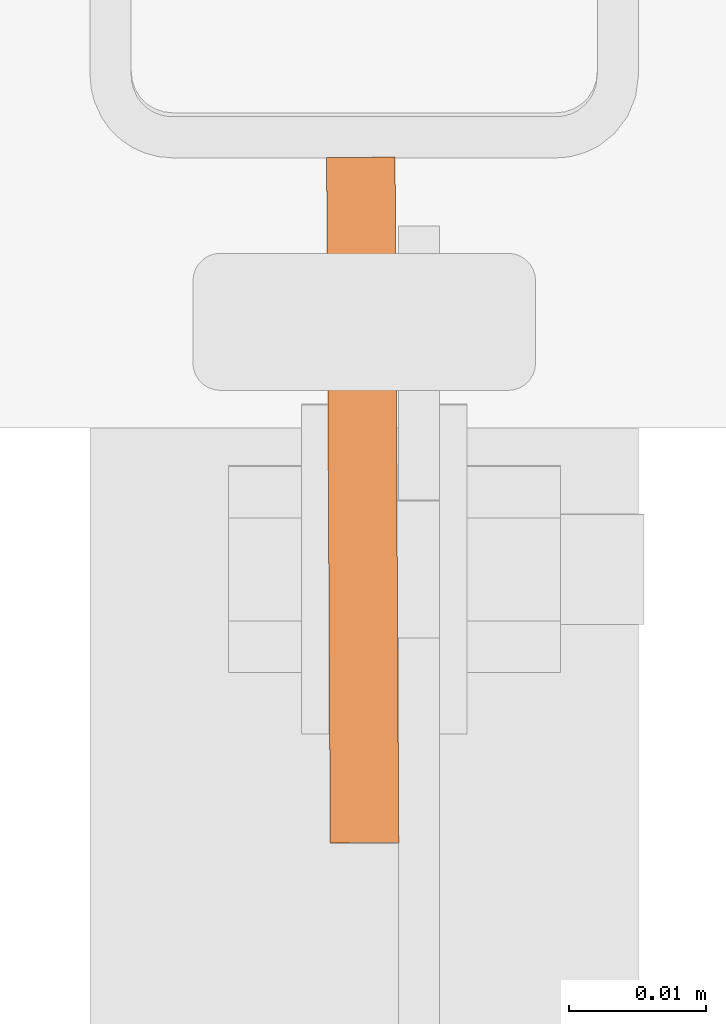
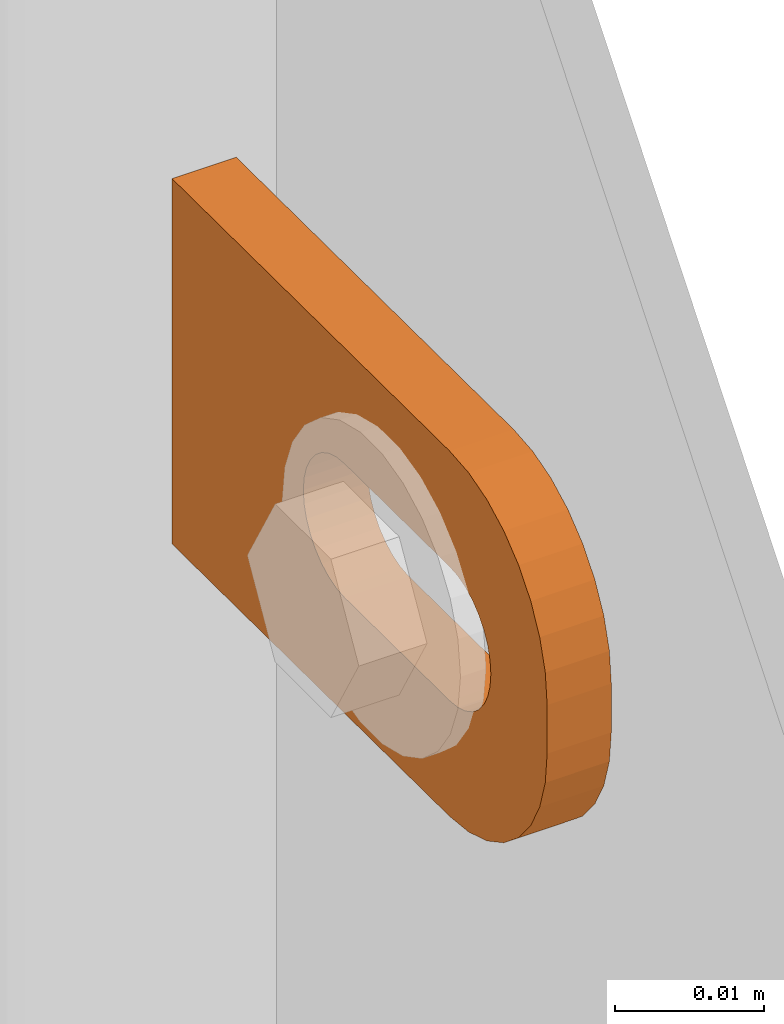
# One storey, part 132 of 156: 1 proxy, 1 element without a shape of its own.
"""IFC2X3 building model written with IfcOpenShell, lengths in millimetres."""

import ifcopenshell
import ifcopenshell.guid

model = None  # the IFC model being written
_history = None  # IfcOwnerHistory: only IFC2X3 demands one
_inside = {}  # id of a spatial element -> (the spatial element, [elements in it])
_under = {}  # id of a project, library or spatial element -> (it, [spatial elements below it])
_declared = {}  # id of a project -> (the project, [libraries it declares])
_typed = {}  # id of a type object -> (the type object, [elements of that type])
_made_of = {}  # id of a material, layer set ... -> (it, [elements and type objects made of it])


def new_model(schema):
    """Start an empty IFC model of exactly this schema.

    Asked for "IFC4X3", IfcOpenShell would pick the latest addendum, in which some entities
    have other attributes; the version numbers below select the first issue.
    IFC2X3 requires an IfcOwnerHistory on every rooted entity: one is made here for all.
    """
    global model, _history
    if schema == "IFC4X3":
        model = ifcopenshell.file(schema_version=(4, 3, 0, 0))
    else:
        model = ifcopenshell.file(schema=schema)
    _inside.clear()
    _under.clear()
    _declared.clear()
    _typed.clear()
    _made_of.clear()
    _history = None
    if model.schema == "IFC2X3":
        org = make("IfcOrganization", Name="unknown")
        user = make(
            "IfcPersonAndOrganization",
            ThePerson=make("IfcPerson", FamilyName="unknown"),
            TheOrganization=org,
        )
        app = make(
            "IfcApplication",
            ApplicationDeveloper=org,
            Version="unknown",
            ApplicationFullName="unknown",
            ApplicationIdentifier="unknown",
        )
        _history = make(
            "IfcOwnerHistory",
            OwningUser=user,
            OwningApplication=app,
            ChangeAction="ADDED",
            CreationDate=0,
        )
    return model


def make(cls, **values):
    """One entity of the class cls with the attributes given. An attribute that is None is left unset."""
    return model.create_entity(
        cls, **{name: value for name, value in values.items() if value is not None}
    )


def rooted(cls, **values):
    """An entity with a GlobalId (a new one), such as an element, a storey or a relation."""
    return make(cls, GlobalId=ifcopenshell.guid.new(), OwnerHistory=_history, **values)


def si_unit(unit_type, name, prefix=None):
    """IfcSIUnit, for example si_unit("LENGTHUNIT", "METRE", prefix="MILLI")."""
    return make("IfcSIUnit", UnitType=unit_type, Prefix=prefix, Name=name)


def assignment(units):
    """IfcUnitAssignment: the units of a project."""
    return None if units is None else make("IfcUnitAssignment", Units=units)


def point(xyz):
    """IfcCartesianPoint."""
    return None if xyz is None else make("IfcCartesianPoint", Coordinates=xyz)


def direction(xyz):
    """IfcDirection."""
    return None if xyz is None else make("IfcDirection", DirectionRatios=xyz)


def frame(location, z_axis=None, x_axis=None):
    """IfcAxis2Placement3D, a coordinate frame: its origin and axes. An axis left out is left unset."""
    return make(
        "IfcAxis2Placement3D",
        Location=point(location),
        Axis=direction(z_axis),
        RefDirection=direction(x_axis),
    )


def origin_with_axes():
    """The frame at (0, 0, 0) with the z axis (0, 0, 1) and the x axis (1, 0, 0) written out."""
    return frame((0.0, 0.0, 0.0), z_axis=(0.0, 0.0, 1.0), x_axis=(1.0, 0.0, 0.0))


def place(relative_to, where):
    """IfcLocalPlacement: puts the frame where relative to a parent placement (None: the world)."""
    return make(
        "IfcLocalPlacement", PlacementRelTo=relative_to, RelativePlacement=where
    )


def context(
    kind, dimensions, precision=None, world=None, true_north=None, identifier=None
):
    """IfcGeometricRepresentationContext, for example the 3D "Model" context."""
    return make(
        "IfcGeometricRepresentationContext",
        ContextIdentifier=identifier,
        ContextType=kind,
        CoordinateSpaceDimension=dimensions,
        Precision=precision,
        WorldCoordinateSystem=world,
        TrueNorth=true_north,
    )


def subcontext(parent, identifier, kind, view, scale=None):
    """IfcGeometricRepresentationSubContext, for example "Body" below "Model"."""
    return make(
        "IfcGeometricRepresentationSubContext",
        ContextIdentifier=identifier,
        ContextType=kind,
        ParentContext=parent,
        TargetScale=scale,
        TargetView=view,
    )


def project(units=None, contexts=None):
    """IfcProject with its units and contexts."""
    return rooted(
        "IfcProject",
        Name="project",
        RepresentationContexts=contexts,
        UnitsInContext=assignment(units),
    )


def spatial(cls, under=None, at=None, **own):
    """A site, building, storey or space (cls), placed at a placement, below another one or the project."""
    s = rooted(cls, ObjectPlacement=at, **own)
    if under is not None:
        _under.setdefault(under.id(), (under, []))[1].append(s)
    return s


def faces_of(points, faces, orient=None, outer=None):
    """IfcFace entities. A face is a list of loops; a loop is a list of indices into points, from 0.

    orient and outer hold one flag for each loop. By default every Orientation is true, the
    first loop of a face is its IfcFaceOuterBound and the others are IfcFaceBound.
    """
    made = []
    for i, loops in enumerate(faces):
        bounds = []
        for j, loop in enumerate(loops):
            is_outer = j == 0 if outer is None else outer[i][j]
            bounds.append(
                make(
                    "IfcFaceOuterBound" if is_outer else "IfcFaceBound",
                    Bound=make("IfcPolyLoop", Polygon=[points[k] for k in loop]),
                    Orientation=True if orient is None else orient[i][j],
                )
            )
        made.append(make("IfcFace", Bounds=bounds))
    return made


def faceted_brep(points, faces, orient=None, outer=None, voids=None):
    """IfcFacetedBrep: a solid bounded by flat faces; with voids (closed shells), ...WithVoids."""
    shared = [point(p) for p in points]
    hull = make("IfcClosedShell", CfsFaces=faces_of(shared, faces, orient, outer))
    if voids is None:
        return make("IfcFacetedBrep", Outer=hull)
    return make(
        "IfcFacetedBrepWithVoids",
        Outer=hull,
        Voids=[
            make(cls, CfsFaces=faces_of(shared, fs, o, b)) for cls, fs, o, b in voids
        ],
    )


def shape(context_of_items, identifier, shape_type, items):
    """IfcShapeRepresentation: the items that make up one representation, for example the "Body"."""
    return make(
        "IfcShapeRepresentation",
        ContextOfItems=context_of_items,
        RepresentationIdentifier=identifier,
        RepresentationType=shape_type,
        Items=items,
    )


def material(Name=None, Category=None):
    """IfcMaterial."""
    return make("IfcMaterial", Name=Name, Category=Category)


def made_of(thing, what):
    """Note that an element or type object is made of a material, layer set ...; save() writes the relation."""
    if what is not None:
        _made_of.setdefault(what.id(), (what, []))[1].append(thing)
    return thing


def type_object(cls, material=None, **own):
    """A type object (cls), such as IfcWallType, which elements share."""
    return made_of(rooted(cls, **own), material)


def element(
    cls,
    number,
    at=None,
    inside=None,
    cuts=None,
    type_object=None,
    material=None,
    context=None,
    identifier="Body",
    shape_type=None,
    held_by="IfcProductDefinitionShape",
    body=None,
    shapes=None,
    **own,
):
    """One element of the class cls, such as IfcWall. Its Tag is "e" and its number.

    at: its placement. inside: the storey or other place that contains it. cuts: it is an
    opening in that element (IfcRelVoidsElement). A single representation is given by context,
    identifier, shape_type and body (its items); several are given by shapes. held_by: the class
    of the entity that holds the representations. save() writes the other relations.
    """
    e = rooted(cls, Tag="e%d" % number, ObjectPlacement=at, **own)
    if body is not None:
        shapes = [shape(context, identifier, shape_type, body)]
    if shapes is not None:
        e.Representation = make(held_by, Representations=shapes)
    if inside is not None:
        _inside.setdefault(inside.id(), (inside, []))[1].append(e)
    if cuts is not None:
        rooted(
            "IfcRelVoidsElement", RelatingBuildingElement=cuts, RelatedOpeningElement=e
        )
    if type_object is not None:
        _typed.setdefault(type_object.id(), (type_object, []))[1].append(e)
    return made_of(e, material)


def aggregate(whole, parts):
    """IfcRelAggregates: a whole, such as a stair, and the parts it consists of."""
    return rooted("IfcRelAggregates", RelatingObject=whole, RelatedObjects=parts)


def save(model, path):
    """Write the relations noted so far, then the file.

    IfcRelAggregates (storeys below a building ...), IfcRelContainedInSpatialStructure (elements
    in a storey), IfcRelDefinesByType, IfcRelAssociatesMaterial and IfcRelDeclares: one each for
    every whole, place, type object, material and project.
    """
    for whole, parts in _under.values():
        aggregate(whole, parts)
    for where, things in _inside.values():
        rooted(
            "IfcRelContainedInSpatialStructure",
            RelatedElements=things,
            RelatingStructure=where,
        )
    for kind, things in _typed.values():
        rooted("IfcRelDefinesByType", RelatedObjects=things, RelatingType=kind)
    for what, things in _made_of.values():
        rooted("IfcRelAssociatesMaterial", RelatedObjects=things, RelatingMaterial=what)
    for by, libraries in _declared.values():
        rooted("IfcRelDeclares", RelatingContext=by, RelatedDefinitions=libraries)
    model.write(path)


model = new_model("IFC2X3")

# Units and contexts
model_context = context("Model", 3, precision=1e-05, world=origin_with_axes())
body_context = subcontext(model_context, "Body", "Model", "MODEL_VIEW")
ifc_project = project(units=[si_unit("LENGTHUNIT", "METRE", prefix="MILLI"), si_unit("AREAUNIT", "SQUARE_METRE"), si_unit("VOLUMEUNIT", "CUBIC_METRE"), si_unit("MASSUNIT", "GRAM", prefix="KILO"), si_unit("TIMEUNIT", "SECOND"), si_unit("PLANEANGLEUNIT", "RADIAN"), si_unit("SOLIDANGLEUNIT", "STERADIAN"), si_unit("THERMODYNAMICTEMPERATUREUNIT", "DEGREE_CELSIUS"), si_unit("LUMINOUSINTENSITYUNIT", "LUMEN")], contexts=[model_context])

# Site, building, storey
site_placement = place(None, origin_with_axes())
site = spatial("IfcSite", under=ifc_project, at=site_placement, CompositionType="ELEMENT")
building_placement = place(site_placement, origin_with_axes())
building = spatial("IfcBuilding", under=site, at=building_placement, Name="Undefined", CompositionType="ELEMENT")
storey_placement = place(building_placement, origin_with_axes())
storey = spatial("IfcBuildingStorey", under=building, at=storey_placement, Name="Undefined", CompositionType="ELEMENT", Elevation=0.0)

# Assembly, proxy
assembly_placement = place(storey_placement, origin_with_axes())
assembly = element("IfcElementAssembly", 1, at=assembly_placement, inside=storey, AssemblyPlace="NOTDEFINED", PredefinedType="RIGID_FRAME")
ifc_material = material(Name="STEEL/S235JR")
building_element_proxy_type = type_object("IfcBuildingElementProxyType", Name="50", PredefinedType="NOTDEFINED")
proxy_placement = place(assembly_placement, frame((14799.75, 23368.0068367617, 3194.79276353919), z_axis=(-0.999985556002151, -0.00537473600001249, 0.0), x_axis=(0.00537473600001187, -0.999985556002151, 1.19999999540802e-08)))
proxy = element("IfcBuildingElementProxy", 2, at=proxy_placement, type_object=building_element_proxy_type, material=ifc_material, ObjectType="50", CompositionType="ELEMENT", context=body_context, shape_type="Brep", body=[
    faceted_brep([(37.0000004768226, -5.50000056624776, -2.49999994410609), (23.0000000446889, -5.50000056624594, -2.49999994410973), (23.0000000446889, -5.50000056624594, 2.49999994413156), (37.000000476819, -5.50000056624776, 2.49999994413338), (21.9270028173814, -5.39431966841403, -2.49999994410973), (21.9270028173778, -5.39431966841403, 2.49999994412792), (20.895240828384, -5.0813375413436, -2.49999994411155), (20.895240828384, -5.0813375413436, 2.49999994412974), (19.9443642049955, -4.5730831474084, -2.49999994410973), (19.9443642049919, -4.5730831474084, 2.49999994412792), (19.1109124571012, -3.88908818364325, -2.49999994411155), (19.1109124571012, -3.88908818364325, 2.49999994412792), (18.4269174933361, -3.05563643574806, -2.49999994411155), (18.4269174933361, -3.05563643574806, 2.4999999441261), (17.9186630994009, -2.1047579497108, -2.49999994411155), (17.9186630994009, -2.1047579497108, 2.49999994412428), (17.6056809723377, -1.07299596071425, -2.49999994411337), (17.6056809723341, -1.07299596071425, 2.4999999441261), (17.5000000745022, 3.3527521736687e-07, -2.49999994411519), (17.5000000745058, 3.3527521736687e-07, 2.49999994412428), (17.6056809723377, 1.07299663126287, -2.49999994411701), (17.6056809723377, 1.07299663126287, 2.49999994412428), (17.9186630994154, 2.10475862026124, -2.49999994411701), (17.9186630994118, 2.10475862026124, 2.49999994412246), (18.426917493347, 3.05563617497592, -2.49999994411701), (18.426917493347, 3.05563617497592, 2.49999994412246), (19.1109124571158, 3.88908699154672, -2.49999994411883), (19.1109124571121, 3.88908699154672, 2.49999994412065), (19.9443642050101, 4.57308288663444, -2.49999994411701), (19.9443642050064, 4.57308288663444, 2.49999994412065), (20.8952408283985, 5.08133728056964, -2.49999994411883), (20.8952408283985, 5.08133728056964, 2.49999994412065), (21.9270028173996, 5.39431940764007, -2.49999994411883), (21.927002817396, 5.39431940764007, 2.49999994412065), (23.0000000447108, 5.50000030547199, -2.49999994411883), (23.0000000447071, 5.50000030547199, 2.49999994412246), (37.0000004768408, 5.50000030547017, -2.49999994411519), (37.0000004768408, 5.50000030547017, 2.49999994412428), (38.0729958415031, 5.39431940763825, -2.49999994411519), (38.0729958414995, 5.39431940763825, 2.49999994412428), (39.1047596931458, 5.08133728056691, -2.49999994411337), (39.1047596931421, 5.08133728056691, 2.49999994412428), (40.0556363165415, 4.57308288663171, -2.49999994411519), (40.0556363165379, 4.57308288663171, 2.4999999441261), (40.8890880644285, 3.8890869915449, -2.49999994411337), (40.8890880644285, 3.8890869915449, 2.49999994412792), (41.5730811655449, 3.05563617497228, -2.49999994411337), (41.5730811655449, 3.05563617497228, 2.4999999441261), (42.0813374221252, 2.1047586202576, -2.49999994411155), (42.0813374221252, 2.1047586202576, 2.49999994412792), (42.3943176865469, 1.07299663126014, -2.49999994410973), (42.3943176865469, 1.07299663126014, 2.49999994412974), (42.5000004470239, 3.35271579388063e-07, -2.49999994410973), (42.5000004470276, 3.35271579388063e-07, 2.49999994412974), (42.3943176865469, -1.07299596071698, -2.49999994410791), (42.3943176865432, -1.07299596071698, 2.49999994413156), (42.0813374221179, -2.10475794971444, -2.49999994410791), (42.0813374221143, -2.10475794971444, 2.49999994413338), (41.5730811655376, -3.05563643575169, -2.49999994410791), (41.5730811655339, -3.05563643575169, 2.49999994413156), (40.8890880644176, -3.88908818364507, -2.49999994410609), (40.889088064414, -3.88908818364507, 2.49999994413338), (40.0556363165233, -4.57308314741113, -2.49999994410791), (40.0556363165233, -4.57308314741113, 2.49999994413338), (39.1047596931276, -5.08133754134633, -2.49999994410609), (39.1047596931276, -5.08133754134633, 2.49999994413338), (38.072995841485, -5.39431966841585, -2.49999994410609), (38.072995841485, -5.39431966841585, 2.49999994413156), (37.0000004768044, -14.9999993294514, 2.49999994414065), (39.5361743867034, -14.7502093017147, 2.49999994414065), (41.9748835265273, -14.0104337036646, 2.49999994414065), (44.222414493528, -12.8091058135078, 2.49999994414247), (46.192388981548, -11.1923875659759, 2.49999994413884), (47.809105366443, -9.22241307795593, 2.49999994413884), (49.010433256597, -6.97488397360394, 2.49999994413702), (49.7502088546535, -4.53617483378002, 2.49999994413338), (50.0000007450435, -2.00000092387745, 2.49999994413338), (50.0000007450471, 1.99999973177364, 2.49999994412974), (49.7502088546717, 4.53617457299879, 2.4999999441261), (49.0104332566261, 6.97488464414528, 2.4999999441261), (47.8091053664721, 9.2224128171747, 2.49999994412428), (46.192388981588, 11.1923882365172, 2.49999994412065), (44.2224144935717, 12.8091048542365, 2.49999994411883), (41.9748835265782, 14.0104339085483, 2.49999994411883), (39.5361743867543, 14.7502086334816, 2.49999994411701), (37.0000004768553, 14.9999999999964, 2.49999994411519), (2.91038304567337e-11, 15.0000000000009, 2.49999994410791), (-2.18278728425503e-11, -14.9999993294468, 2.49999994413338), (3.27418092638254e-11, 15.0000000000009, -2.49999994413156), (-2.18278728425503e-11, -14.9999993294468, -2.49999994410791), (37.0000004768008, -14.9999993294514, -2.49999994409882), (39.5361743867034, -14.7502093017147, -2.49999994409882), (41.9748835265309, -14.0104337036646, -2.499999944097), (44.222414493528, -12.8091058135078, -2.49999994409882), (46.1923889815516, -11.1923875659759, -2.49999994409882), (47.8091053664393, -9.22241307795593, -2.49999994410064), (49.0104332566007, -6.97488397360394, -2.49999994410246), (49.7502088546535, -4.53617483378002, -2.49999994410609), (50.0000007450435, -2.00000092387745, -2.49999994410609), (50.0000007450508, 1.99999973177364, -2.49999994410973), (49.750208854668, 4.53617457299879, -2.49999994411155), (49.0104332566261, 6.97488464414528, -2.49999994411337), (47.8091053664721, 9.2224128171747, -2.49999994411519), (46.1923889815916, 11.1923882365172, -2.49999994411883), (44.2224144935717, 12.8091048542365, -2.49999994411883), (41.9748835265782, 14.0104339085483, -2.49999994412065), (39.5361743867579, 14.7502086334816, -2.49999994412246), (37.000000476859, 14.9999999999964, -2.49999994412428)], [[[0, 1, 2, 3]], [[1, 4, 5, 2]], [[4, 6, 7, 5]], [[6, 8, 9, 7]], [[8, 10, 11, 9]], [[10, 12, 13, 11]], [[12, 14, 15, 13]], [[14, 16, 17, 15]], [[16, 18, 19, 17]], [[18, 20, 21, 19]], [[20, 22, 23, 21]], [[22, 24, 25, 23]], [[24, 26, 27, 25]], [[26, 28, 29, 27]], [[28, 30, 31, 29]], [[30, 32, 33, 31]], [[32, 34, 35, 33]], [[34, 36, 37, 35]], [[36, 38, 39, 37]], [[38, 40, 41, 39]], [[40, 42, 43, 41]], [[42, 44, 45, 43]], [[44, 46, 47, 45]], [[46, 48, 49, 47]], [[48, 50, 51, 49]], [[50, 52, 53, 51]], [[52, 54, 55, 53]], [[54, 56, 57, 55]], [[56, 58, 59, 57]], [[58, 60, 61, 59]], [[60, 62, 63, 61]], [[62, 64, 65, 63]], [[64, 66, 67, 65]], [[66, 0, 3, 67]], [[68, 69, 70, 71, 72, 73, 74, 75, 76, 77, 78, 79, 80, 81, 82, 83, 84, 85, 86, 87], [5, 7, 9, 11, 13, 15, 17, 19, 21, 23, 25, 27, 29, 31, 33, 35, 37, 39, 41, 43, 45, 47, 49, 51, 53, 55, 57, 59, 61, 63, 65, 67, 3, 2]], [[86, 88, 89, 87]], [[87, 89, 90, 68]], [[68, 90, 91, 69]], [[69, 91, 92, 70]], [[70, 92, 93, 71]], [[71, 93, 94, 72]], [[72, 94, 95, 73]], [[73, 95, 96, 74]], [[74, 96, 97, 75]], [[75, 97, 98, 76]], [[76, 98, 99, 77]], [[77, 99, 100, 78]], [[78, 100, 101, 79]], [[79, 101, 102, 80]], [[80, 102, 103, 81]], [[81, 103, 104, 82]], [[82, 104, 105, 83]], [[83, 105, 106, 84]], [[84, 106, 107, 85]], [[85, 107, 88, 86]], [[105, 104, 103, 102, 101, 100, 99, 98, 97, 96, 95, 94, 93, 92, 91, 90, 89, 88, 107, 106], [60, 58, 56, 54, 52, 50, 48, 46, 44, 42, 40, 38, 36, 34, 32, 30, 28, 26, 24, 22, 20, 18, 16, 14, 12, 10, 8, 6, 4, 1, 0, 66, 64, 62]]]),
])
aggregate(assembly, [proxy])

save(model, "model.ifc")
